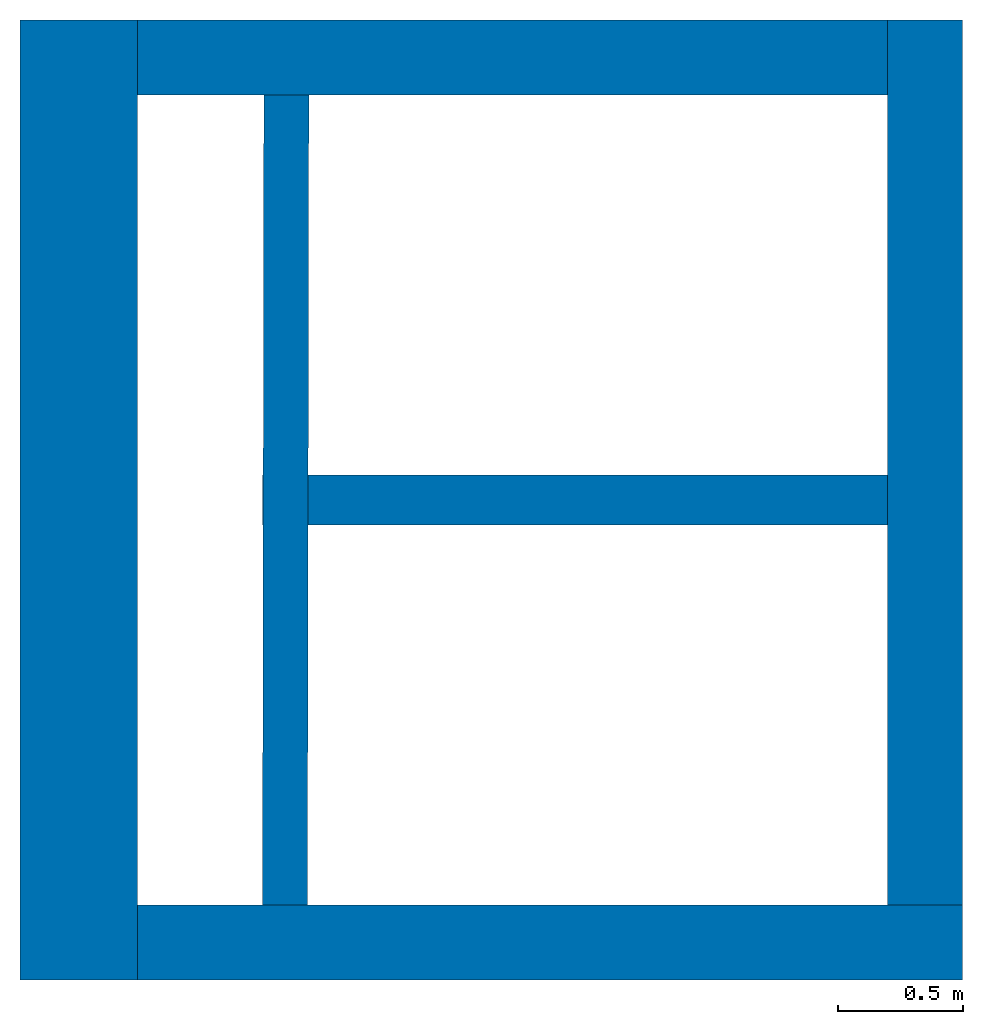
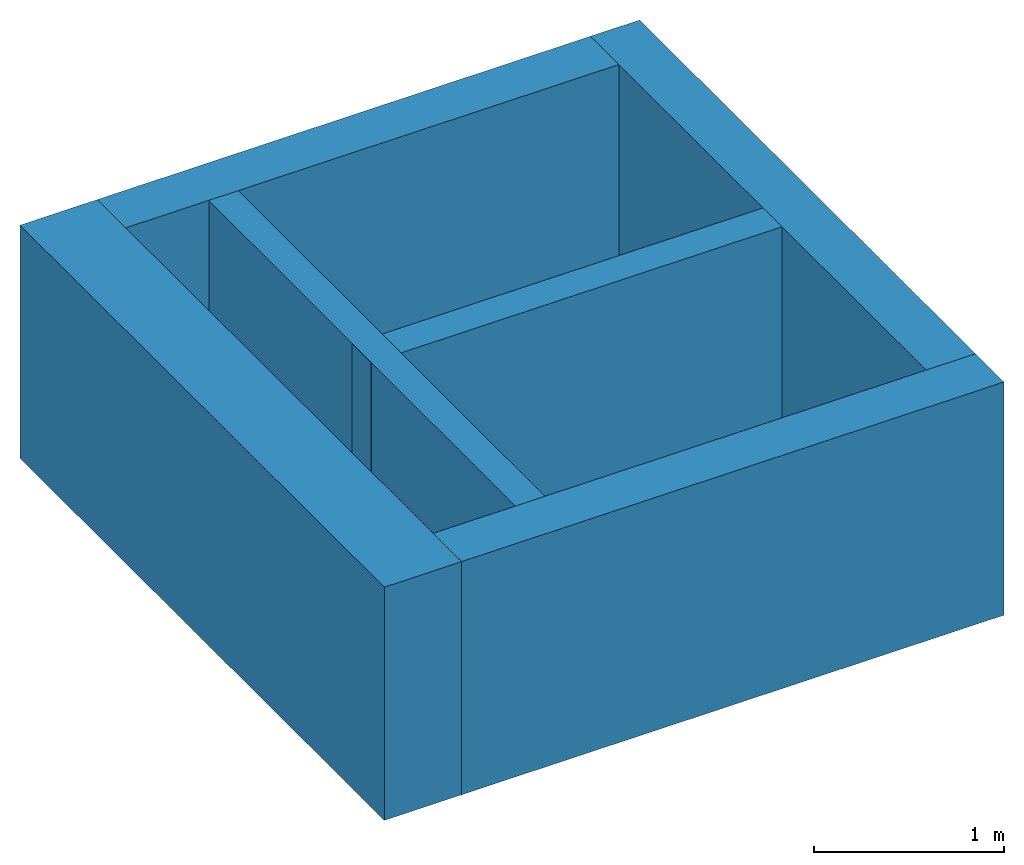
# One storey: 6 walls.
"""IFC4 building model written with IfcOpenShell, lengths in metres."""

from ifc_helpers import new_model, entity, si_unit, converted_unit, derived_unit, direction, frame, origin_with_axes, place, context, subcontext, project, spatial, polygons, material, type_object, element, save


model = new_model("IFC4")

# Units and contexts
model_context = context("Model", 3, precision=1e-05, world=origin_with_axes(), true_north=direction((0.0, 1.0)))
body_context = subcontext(model_context, "Body", "Model", "MODEL_VIEW")
ifc_project = project(units=[si_unit("LENGTHUNIT", "METRE"), si_unit("AREAUNIT", "SQUARE_METRE"), si_unit("VOLUMEUNIT", "CUBIC_METRE"), converted_unit("PLANEANGLEUNIT", "DEGREE", entity("IfcPlaneAngleMeasure", 0.0174532925199433), si_unit("PLANEANGLEUNIT", "RADIAN"), dimensions=[0, 0, 0, 0, 0, 0, 0]), converted_unit("TIMEUNIT", "Year", entity("IfcTimeMeasure", 31557600.0), si_unit("TIMEUNIT", "SECOND"), dimensions=[0, 0, 1, 0, 0, 0, 0]), si_unit("MASSUNIT", "GRAM", prefix="KILO"), si_unit("THERMODYNAMICTEMPERATUREUNIT", "DEGREE_CELSIUS"), si_unit("LUMINOUSINTENSITYUNIT", "LUMEN"), si_unit("ENERGYUNIT", "JOULE", prefix="MEGA"), derived_unit("THERMALCONDUCTANCEUNIT", [(si_unit("POWERUNIT", "WATT"), 1), (si_unit("LENGTHUNIT", "METRE"), -1), (si_unit("THERMODYNAMICTEMPERATUREUNIT", "KELVIN"), -1)]), derived_unit("SPECIFICHEATCAPACITYUNIT", [(si_unit("ENERGYUNIT", "JOULE"), 1), (si_unit("MASSUNIT", "GRAM", prefix="KILO"), -1), (si_unit("THERMODYNAMICTEMPERATUREUNIT", "KELVIN"), -1)]), derived_unit("MASSDENSITYUNIT", [(si_unit("MASSUNIT", "GRAM", prefix="KILO"), 1), (si_unit("VOLUMEUNIT", "CUBIC_METRE"), -1)])], contexts=[model_context])

# Site, building, storey
site_placement = place(None, origin_with_axes())
site = spatial("IfcSite", under=ifc_project, at=site_placement, CompositionType="ELEMENT")
building_placement = place(None, origin_with_axes())
building = spatial("IfcBuilding", under=site, at=building_placement, CompositionType="ELEMENT")
storey_placement = place(None, frame((0.0, 0.0, -6.0), z_axis=(0.0, 0.0, 1.0), x_axis=(1.0, 0.0, 0.0)))
storey = spatial("IfcBuildingStorey", under=building, at=storey_placement, Name="FU", CompositionType="ELEMENT", Elevation=-6.0)

# Walls
ifc_material = material(Name="Stahlbeton")
wall_type_1 = type_object("IfcWallType", Name="Stahlbeton 180", PredefinedType="NOTDEFINED")
wall_1_placement = place(None, frame((29.1375075990708, 6.93499994546755, -4.5), z_axis=(0.0, 0.0, 1.0), x_axis=(0.00164133421967388, 0.999998653010083, 0.0)))
element("IfcWall", 1, at=wall_1_placement, inside=storey, type_object=wall_type_1, material=ifc_material, Name="Wand-001", PredefinedType="NOTDEFINED", context=body_context, shape_type="Tessellation", body=[
    polygons([(0.299704963540022, 0.18, 0.0), (3.53970932779323, 0.180000000000007, 0.0), (3.54000476835073, 0.0, 0.0), (0.30000040409752, 0.0, 0.0), (0.299704963540022, 0.18, 1.5), (3.53970932779323, 0.180000000000007, 1.5), (3.54000476835073, 0.0, 1.5), (0.30000040409752, 0.0, 1.5)], [[[1, 2, 3, 4]], [[5, 6, 2, 1]], [[7, 3, 2, 6]], [[4, 3, 7, 8]], [[8, 5, 1, 4]], [[8, 7, 6, 5]]], closed=True),
])
wall_type_2 = type_object("IfcWallType", Name="Stahlbeton 470", PredefinedType="NOTDEFINED")
wall_2_placement = place(None, frame((27.988, 10.7749999454676, -4.5), z_axis=(0.0, 0.0, 1.0), x_axis=(0.0, -1.0, 0.0)))
element("IfcWall", 2, at=wall_2_placement, inside=storey, type_object=wall_type_2, material=ifc_material, Name="Wand-003", PredefinedType="NOTDEFINED", context=body_context, shape_type="Tessellation", body=[
    polygons([(3.84, 0.469999999999999, 0.0), (3.84, 0.0, 0.0), (0.0, 0.0, 0.0), (0.0, 0.469999999999999, 0.0), (3.84, 0.469999999999999, 1.5), (3.84, 0.0, 1.5), (0.0, 0.0, 1.5), (0.0, 0.469999999999999, 1.5)], [[[1, 2, 3, 4]], [[2, 1, 5, 6]], [[2, 6, 7, 3]], [[8, 4, 3, 7]], [[5, 1, 4, 8]], [[6, 5, 8, 7]]], closed=True),
])
wall_type_3 = type_object("IfcWallType", Name="Stahlbeton 300", PredefinedType="NOTDEFINED")
wall_3_placement = place(None, frame((27.988, 6.93499994546755, -4.5), z_axis=(0.0, 0.0, 1.0), x_axis=(1.0, 0.0, 0.0)))
element("IfcWall", 3, at=wall_3_placement, inside=storey, type_object=wall_type_3, material=ifc_material, Name="Wand-001", PredefinedType="NOTDEFINED", context=body_context, shape_type="Tessellation", body=[
    polygons([(3.77, 0.300000000000002, 0.0), (3.77, 0.0, 0.0), (0.469999999999999, 0.0, 0.0), (0.469999999999999, 0.3, 0.0), (3.77, 0.300000000000002, 1.5), (3.77, 0.0, 1.5), (0.469999999999999, 0.0, 1.5), (0.469999999999999, 0.3, 1.5)], [[[1, 2, 3, 4]], [[2, 1, 5, 6]], [[2, 6, 7, 3]], [[8, 4, 3, 7]], [[5, 1, 4, 8]], [[6, 5, 8, 7]]], closed=True),
])
wall_4_placement = place(None, frame((31.758, 10.7749999454676, -4.5), z_axis=(0.0, 0.0, 1.0), x_axis=(-1.0, 0.0, 0.0)))
element("IfcWall", 4, at=wall_4_placement, inside=storey, type_object=wall_type_3, material=ifc_material, Name="Wand-003", PredefinedType="NOTDEFINED", context=body_context, shape_type="Tessellation", body=[
    polygons([(3.3, 0.299999999999999, 0.0), (3.3, 0.0, 0.0), (0.300000000000001, 0.0, 0.0), (0.300000000000001, 0.300000000000001, 0.0), (3.3, 0.300000000000001, 1.5), (3.3, 0.0, 1.5), (0.300000000000001, 0.0, 1.5), (0.300000000000001, 0.300000000000001, 1.5)], [[[1, 2, 3, 4]], [[2, 1, 5, 6]], [[2, 6, 7, 3]], [[8, 4, 3, 7]], [[5, 1, 4, 8]], [[6, 5, 8, 7]]], closed=True),
])
wall_5_placement = place(None, frame((31.758, 6.93499994546755, -4.5), z_axis=(0.0, 0.0, 1.0), x_axis=(0.0, 1.0, 0.0)))
element("IfcWall", 5, at=wall_5_placement, inside=storey, type_object=wall_type_3, material=ifc_material, Name="Wand-002", PredefinedType="NOTDEFINED", context=body_context, shape_type="Tessellation", body=[
    polygons([(3.84000000000001, 0.299999999999997, 0.0), (3.84, 0.0, 0.0), (0.3, 0.0, 0.0), (0.3, 0.300000000000001, 0.0), (3.84000000000001, 0.299999999999997, 1.5), (3.84, 0.0, 1.5), (0.3, 0.0, 1.5), (0.3, 0.300000000000001, 1.5)], [[[1, 2, 3, 4]], [[2, 1, 5, 6]], [[2, 6, 7, 3]], [[8, 4, 3, 7]], [[5, 1, 4, 8]], [[6, 5, 8, 7]]], closed=True),
])
wall_type_4 = type_object("IfcWallType", Name="Stahlbeton 200", PredefinedType="NOTDEFINED")
wall_6_placement = place(None, frame((28.958, 8.85499994546755, -4.5), z_axis=(0.0, 0.0, 1.0), x_axis=(1.0, 0.0, 0.0)))
element("IfcWall", 6, at=wall_6_placement, inside=storey, type_object=wall_type_4, material=ifc_material, Name="Wand-001", PredefinedType="NOTDEFINED", context=body_context, shape_type="Tessellation", body=[
    polygons([(0.00282285620201605, 0.0999999999999996, 0.0), (0.00249458891590493, -0.0999999999999996, 0.0), (0.0, -0.0999999999999996, 0.0), (0.0, 0.0999999999999996, 0.0), (0.00282285620201605, 0.0999999999999996, 1.5), (0.00249458891590493, -0.0999999999999996, 1.5), (0.0, -0.0999999999999996, 1.5), (0.0, 0.0999999999999996, 1.5)], [[[1, 2, 3, 4]], [[2, 1, 5, 6]], [[2, 6, 7, 3]], [[8, 4, 3, 7]], [[5, 1, 4, 8]], [[6, 5, 8, 7]]], closed=True),
    polygons([(2.5, 0.0999999999999996, 0.0), (2.5, -0.0999999999999996, 0.0), (0.182494831374417, -0.0999999999999996, 0.0), (0.182823098660528, 0.0999999999999996, 0.0), (2.5, 0.0999999999999996, 1.5), (2.5, -0.0999999999999996, 1.5), (0.182494831374417, -0.0999999999999996, 1.5), (0.182823098660528, 0.0999999999999996, 1.5)], [[[1, 2, 3, 4]], [[2, 1, 5, 6]], [[2, 6, 7, 3]], [[8, 4, 3, 7]], [[5, 1, 4, 8]], [[6, 5, 8, 7]]], closed=True),
])

save(model, "model.ifc")
